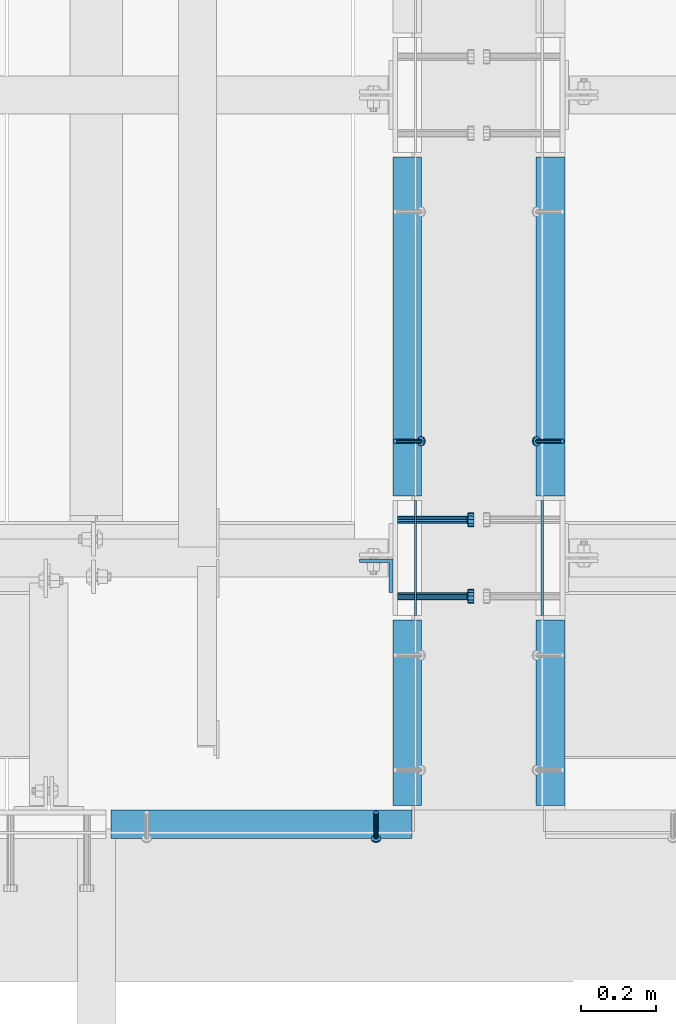
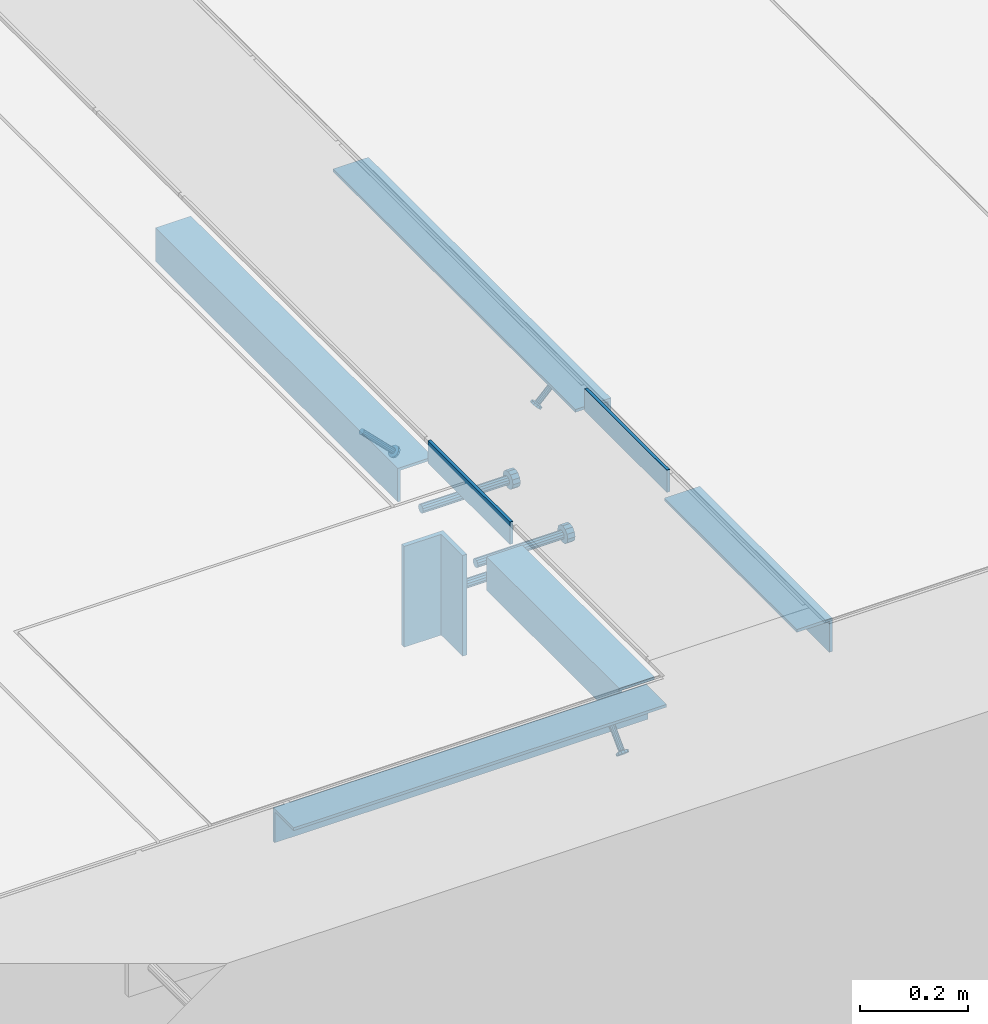
# One storey, part 2047 of 3843: 11 beams, 3 members, 8 elements without a shape of their own.
"""IFC2X3 building model written with IfcOpenShell, lengths in millimetres."""

import ifcopenshell
import ifcopenshell.guid

model = None  # the IFC model being written
_history = None  # IfcOwnerHistory: only IFC2X3 demands one
_inside = {}  # id of a spatial element -> (the spatial element, [elements in it])
_under = {}  # id of a project, library or spatial element -> (it, [spatial elements below it])
_declared = {}  # id of a project -> (the project, [libraries it declares])
_typed = {}  # id of a type object -> (the type object, [elements of that type])
_made_of = {}  # id of a material, layer set ... -> (it, [elements and type objects made of it])


def new_model(schema):
    """Start an empty IFC model of exactly this schema.

    Asked for "IFC4X3", IfcOpenShell would pick the latest addendum, in which some entities
    have other attributes; the version numbers below select the first issue.
    IFC2X3 requires an IfcOwnerHistory on every rooted entity: one is made here for all.
    """
    global model, _history
    if schema == "IFC4X3":
        model = ifcopenshell.file(schema_version=(4, 3, 0, 0))
    else:
        model = ifcopenshell.file(schema=schema)
    _inside.clear()
    _under.clear()
    _declared.clear()
    _typed.clear()
    _made_of.clear()
    _history = None
    if model.schema == "IFC2X3":
        org = make("IfcOrganization", Name="unknown")
        user = make(
            "IfcPersonAndOrganization",
            ThePerson=make("IfcPerson", FamilyName="unknown"),
            TheOrganization=org,
        )
        app = make(
            "IfcApplication",
            ApplicationDeveloper=org,
            Version="unknown",
            ApplicationFullName="unknown",
            ApplicationIdentifier="unknown",
        )
        _history = make(
            "IfcOwnerHistory",
            OwningUser=user,
            OwningApplication=app,
            ChangeAction="ADDED",
            CreationDate=0,
        )
    return model


def make(cls, **values):
    """One entity of the class cls with the attributes given. An attribute that is None is left unset."""
    return model.create_entity(
        cls, **{name: value for name, value in values.items() if value is not None}
    )


def rooted(cls, **values):
    """An entity with a GlobalId (a new one), such as an element, a storey or a relation."""
    return make(cls, GlobalId=ifcopenshell.guid.new(), OwnerHistory=_history, **values)


def si_unit(unit_type, name, prefix=None):
    """IfcSIUnit, for example si_unit("LENGTHUNIT", "METRE", prefix="MILLI")."""
    return make("IfcSIUnit", UnitType=unit_type, Prefix=prefix, Name=name)


def assignment(units):
    """IfcUnitAssignment: the units of a project."""
    return None if units is None else make("IfcUnitAssignment", Units=units)


def point(xyz):
    """IfcCartesianPoint."""
    return None if xyz is None else make("IfcCartesianPoint", Coordinates=xyz)


def direction(xyz):
    """IfcDirection."""
    return None if xyz is None else make("IfcDirection", DirectionRatios=xyz)


def frame(location, z_axis=None, x_axis=None):
    """IfcAxis2Placement3D, a coordinate frame: its origin and axes. An axis left out is left unset."""
    return make(
        "IfcAxis2Placement3D",
        Location=point(location),
        Axis=direction(z_axis),
        RefDirection=direction(x_axis),
    )


def origin_with_axes():
    """The frame at (0, 0, 0) with the z axis (0, 0, 1) and the x axis (1, 0, 0) written out."""
    return frame((0.0, 0.0, 0.0), z_axis=(0.0, 0.0, 1.0), x_axis=(1.0, 0.0, 0.0))


def place(relative_to, where):
    """IfcLocalPlacement: puts the frame where relative to a parent placement (None: the world)."""
    return make(
        "IfcLocalPlacement", PlacementRelTo=relative_to, RelativePlacement=where
    )


def context(
    kind, dimensions, precision=None, world=None, true_north=None, identifier=None
):
    """IfcGeometricRepresentationContext, for example the 3D "Model" context."""
    return make(
        "IfcGeometricRepresentationContext",
        ContextIdentifier=identifier,
        ContextType=kind,
        CoordinateSpaceDimension=dimensions,
        Precision=precision,
        WorldCoordinateSystem=world,
        TrueNorth=true_north,
    )


def subcontext(parent, identifier, kind, view, scale=None):
    """IfcGeometricRepresentationSubContext, for example "Body" below "Model"."""
    return make(
        "IfcGeometricRepresentationSubContext",
        ContextIdentifier=identifier,
        ContextType=kind,
        ParentContext=parent,
        TargetScale=scale,
        TargetView=view,
    )


def project(units=None, contexts=None):
    """IfcProject with its units and contexts."""
    return rooted(
        "IfcProject",
        Name="project",
        RepresentationContexts=contexts,
        UnitsInContext=assignment(units),
    )


def spatial(cls, under=None, at=None, **own):
    """A site, building, storey or space (cls), placed at a placement, below another one or the project."""
    s = rooted(cls, ObjectPlacement=at, **own)
    if under is not None:
        _under.setdefault(under.id(), (under, []))[1].append(s)
    return s


def faces_of(points, faces, orient=None, outer=None):
    """IfcFace entities. A face is a list of loops; a loop is a list of indices into points, from 0.

    orient and outer hold one flag for each loop. By default every Orientation is true, the
    first loop of a face is its IfcFaceOuterBound and the others are IfcFaceBound.
    """
    made = []
    for i, loops in enumerate(faces):
        bounds = []
        for j, loop in enumerate(loops):
            is_outer = j == 0 if outer is None else outer[i][j]
            bounds.append(
                make(
                    "IfcFaceOuterBound" if is_outer else "IfcFaceBound",
                    Bound=make("IfcPolyLoop", Polygon=[points[k] for k in loop]),
                    Orientation=True if orient is None else orient[i][j],
                )
            )
        made.append(make("IfcFace", Bounds=bounds))
    return made


def faceted_brep(points, faces, orient=None, outer=None, voids=None):
    """IfcFacetedBrep: a solid bounded by flat faces; with voids (closed shells), ...WithVoids."""
    shared = [point(p) for p in points]
    hull = make("IfcClosedShell", CfsFaces=faces_of(shared, faces, orient, outer))
    if voids is None:
        return make("IfcFacetedBrep", Outer=hull)
    return make(
        "IfcFacetedBrepWithVoids",
        Outer=hull,
        Voids=[
            make(cls, CfsFaces=faces_of(shared, fs, o, b)) for cls, fs, o, b in voids
        ],
    )


def shape(context_of_items, identifier, shape_type, items):
    """IfcShapeRepresentation: the items that make up one representation, for example the "Body"."""
    return make(
        "IfcShapeRepresentation",
        ContextOfItems=context_of_items,
        RepresentationIdentifier=identifier,
        RepresentationType=shape_type,
        Items=items,
    )


def material(Name=None, Category=None):
    """IfcMaterial."""
    return make("IfcMaterial", Name=Name, Category=Category)


def made_of(thing, what):
    """Note that an element or type object is made of a material, layer set ...; save() writes the relation."""
    if what is not None:
        _made_of.setdefault(what.id(), (what, []))[1].append(thing)
    return thing


def type_object(cls, material=None, **own):
    """A type object (cls), such as IfcWallType, which elements share."""
    return made_of(rooted(cls, **own), material)


def element(
    cls,
    number,
    at=None,
    inside=None,
    cuts=None,
    type_object=None,
    material=None,
    context=None,
    identifier="Body",
    shape_type=None,
    held_by="IfcProductDefinitionShape",
    body=None,
    shapes=None,
    **own,
):
    """One element of the class cls, such as IfcWall. Its Tag is "e" and its number.

    at: its placement. inside: the storey or other place that contains it. cuts: it is an
    opening in that element (IfcRelVoidsElement). A single representation is given by context,
    identifier, shape_type and body (its items); several are given by shapes. held_by: the class
    of the entity that holds the representations. save() writes the other relations.
    """
    e = rooted(cls, Tag="e%d" % number, ObjectPlacement=at, **own)
    if body is not None:
        shapes = [shape(context, identifier, shape_type, body)]
    if shapes is not None:
        e.Representation = make(held_by, Representations=shapes)
    if inside is not None:
        _inside.setdefault(inside.id(), (inside, []))[1].append(e)
    if cuts is not None:
        rooted(
            "IfcRelVoidsElement", RelatingBuildingElement=cuts, RelatedOpeningElement=e
        )
    if type_object is not None:
        _typed.setdefault(type_object.id(), (type_object, []))[1].append(e)
    return made_of(e, material)


def aggregate(whole, parts):
    """IfcRelAggregates: a whole, such as a stair, and the parts it consists of."""
    return rooted("IfcRelAggregates", RelatingObject=whole, RelatedObjects=parts)


def save(model, path):
    """Write the relations noted so far, then the file.

    IfcRelAggregates (storeys below a building ...), IfcRelContainedInSpatialStructure (elements
    in a storey), IfcRelDefinesByType, IfcRelAssociatesMaterial and IfcRelDeclares: one each for
    every whole, place, type object, material and project.
    """
    for whole, parts in _under.values():
        aggregate(whole, parts)
    for where, things in _inside.values():
        rooted(
            "IfcRelContainedInSpatialStructure",
            RelatedElements=things,
            RelatingStructure=where,
        )
    for kind, things in _typed.values():
        rooted("IfcRelDefinesByType", RelatedObjects=things, RelatingType=kind)
    for what, things in _made_of.values():
        rooted("IfcRelAssociatesMaterial", RelatedObjects=things, RelatingMaterial=what)
    for by, libraries in _declared.values():
        rooted("IfcRelDeclares", RelatingContext=by, RelatedDefinitions=libraries)
    model.write(path)


model = new_model("IFC2X3")

# Units and contexts
model_context = context("Model", 3, precision=1e-05, world=origin_with_axes())
body_context = subcontext(model_context, "Body", "Model", "MODEL_VIEW")
ifc_project = project(units=[si_unit("LENGTHUNIT", "METRE", prefix="MILLI"), si_unit("AREAUNIT", "SQUARE_METRE"), si_unit("VOLUMEUNIT", "CUBIC_METRE"), si_unit("MASSUNIT", "GRAM", prefix="KILO"), si_unit("TIMEUNIT", "SECOND"), si_unit("PLANEANGLEUNIT", "RADIAN"), si_unit("SOLIDANGLEUNIT", "STERADIAN"), si_unit("THERMODYNAMICTEMPERATUREUNIT", "DEGREE_CELSIUS"), si_unit("LUMINOUSINTENSITYUNIT", "LUMEN")], contexts=[model_context])

# Site, building, storey
site_placement = place(None, origin_with_axes())
site = spatial("IfcSite", under=ifc_project, at=site_placement, CompositionType="ELEMENT")
building_placement = place(site_placement, origin_with_axes())
building = spatial("IfcBuilding", under=site, at=building_placement, Name="Undefined", CompositionType="ELEMENT")
storey_placement = place(building_placement, origin_with_axes())
storey = spatial("IfcBuildingStorey", under=building, at=storey_placement, Name="Undefined", CompositionType="ELEMENT", Elevation=0.0)

# Assembly, beam
assembly_1_placement = place(storey_placement, origin_with_axes())
assembly_1 = element("IfcElementAssembly", 1, at=assembly_1_placement, inside=storey, Name="EMBED PLATE", AssemblyPlace="NOTDEFINED", PredefinedType="RIGID_FRAME")
ifc_material_1 = material(Name="STEEL/A36")
beam_type_1 = type_object("IfcBeamType", PredefinedType="NOTDEFINED")
beam_1_placement = place(assembly_1_placement, frame((59013.7249969482, 15151.1, 30454.6), z_axis=(0.0, 0.0, 1.0), x_axis=(0.0, -1.0, 0.0)))
beam_1 = element("IfcBeam", 2, at=beam_1_placement, type_object=beam_type_1, material=ifc_material_1, Name="PLATE", context=body_context, shape_type="Brep", body=[
    faceted_brep([(0.0, 3.17499999999927, -25.4000000000015), (0.0, 3.17499999999927, 25.4000000000015), (304.800000000003, 3.17500000000291, 25.4000000000015), (304.800000000003, 3.17500000000291, -25.4000000000015), (0.0, -3.17499999999927, 25.4000000000015), (304.800000000003, -3.17500000000291, 25.4000000000015), (0.0, -3.17499999999927, -25.4000000000015), (304.800000000003, -3.17500000000291, -25.4000000000015)], [[[0, 1, 2, 3]], [[1, 4, 5, 2]], [[4, 6, 7, 5]], [[6, 0, 3, 7]], [[5, 7, 3, 2]], [[6, 4, 1, 0]]]),
])

assembly_2_placement = place(storey_placement, origin_with_axes())
assembly_2 = element("IfcElementAssembly", 3, at=assembly_2_placement, inside=storey, Name="EMBED PLATE", AssemblyPlace="NOTDEFINED", PredefinedType="RIGID_FRAME")
beam_2_placement = place(assembly_2_placement, frame((59350.2750030518, 14846.3, 30454.6), z_axis=(0.0, 0.0, 1.0), x_axis=(0.0, 1.0, 0.0)))
beam_2 = element("IfcBeam", 4, at=beam_2_placement, type_object=beam_type_1, material=ifc_material_1, Name="PLATE", context=body_context, shape_type="Brep", body=[
    faceted_brep([(0.0, 3.17499999999927, -25.4000000000015), (0.0, 3.17499999999927, 25.4000000000015), (304.800000000003, 3.17500000000291, 25.4000000000015), (304.800000000003, 3.17500000000291, -25.4000000000015), (0.0, -3.17499999999927, 25.4000000000015), (304.800000000003, -3.17500000000291, 25.4000000000015), (0.0, -3.17499999999927, -25.4000000000015), (304.800000000003, -3.17500000000291, -25.4000000000015)], [[[0, 1, 2, 3]], [[1, 4, 5, 2]], [[4, 6, 7, 5]], [[6, 0, 3, 7]], [[5, 7, 3, 2]], [[6, 4, 1, 0]]]),
])
aggregate(assembly_2, [beam_2])

# Assembly, member
assembly_3_placement = place(storey_placement, origin_with_axes())
assembly_3 = element("IfcElementAssembly", 5, at=assembly_3_placement, inside=storey, Name="ANGLE", AssemblyPlace="NOTDEFINED", PredefinedType="RIGID_FRAME")
ifc_material_2 = material(Name="STEEL/A108")
member_type = type_object("IfcMemberType", PredefinedType="NOTDEFINED")
member_1_placement = place(assembly_3_placement, frame((59404.2499894523, 15309.0559967422, 30422.8500045777), z_axis=(0.0, -1.0, 0.0), x_axis=(-0.707106781186548, 0.0, -0.707106781186548)))
member_1 = element("IfcMember", 6, at=member_1_placement, type_object=member_type, material=ifc_material_2, Name="HEADED STUD ANCHOR", context=body_context, shape_type="Brep", body=[
    faceted_brep([(7.27595761418343e-12, -3.18000006675175, 5.5), (0.0, -5.49999999998363, 3.1800000667572), (94.4879985803855, -5.50000000011278, 3.1800000667572), (94.4879985803782, -3.18000006687362, 5.5), (0.0, -6.3499999046162, 0.0), (94.4879985803855, -6.34999990474535, 0.0), (0.0, -5.49999999998363, -3.1800000667572), (94.4879985803855, -5.50000000011278, -3.1800000667572), (7.27595761418343e-12, -3.18000006675175, -5.5), (94.4879985803782, -3.18000006687362, -5.5), (7.27595761418343e-12, -1.81898940354586e-12, -6.34999990463257), (94.4879985803782, -1.20053300634027e-10, -6.34999990463257), (0.0, 3.18000006675175, -5.5), (94.4879985803709, 3.18000006663351, -5.5), (7.27595761418343e-12, 5.49999999998363, -3.1800000667572), (94.4879985803709, 5.49999999987267, -3.1800000667572), (7.27595761418343e-12, 6.3499999046162, 0.0), (94.4879985803673, 6.34999990450706, 0.0), (7.27595761418343e-12, 5.49999999998363, 3.1800000667572), (94.4879985803709, 5.49999999987267, 3.1800000667572), (0.0, 3.18000006675175, 5.5), (94.4879985803709, 3.18000006663351, 5.5), (7.27595761418343e-12, -1.81898940354586e-12, 6.34999990463257), (94.4879985803782, -1.20053300634027e-10, 6.34999990463257), (96.5199985498621, -10.9899997712273, 6.34999990463257), (96.5199985498548, -6.34000015270249, 10.9899997711182), (96.5199985498621, -12.6999998093743, 0.0), (96.5199985498621, -10.9899997712273, -6.34999990463257), (96.5199985498548, -6.34000015270249, -10.9899997711182), (96.5199985498475, -1.21872290037572e-10, -12.6899995803833), (96.5199985498402, 6.34000015245874, -10.9899997711182), (96.519998549833, 10.9899997709817, -6.34999990463257), (96.519998549833, 12.6999998091305, 0.0), (96.519998549833, 10.9899997709817, 6.34999990463257), (96.5199985498402, 6.34000015245874, 10.9899997711182), (96.5199985498475, -1.21872290037572e-10, 12.6899995803833), (101.599998473539, -10.9899997712328, 6.34999990463257), (101.599998473532, -6.34000015270976, 10.9899997711182), (101.599998473539, -12.6999998093797, 0.0), (101.599998473539, -10.9899997712328, -6.34999990463257), (101.599998473532, -6.34000015270976, -10.9899997711182), (101.599998473524, -1.29148247651756e-10, -12.6899995803833), (101.599998473517, 6.34000015245329, -10.9899997711182), (101.59999847351, 10.9899997709763, -6.34999990463257), (101.599998473503, 12.6999998091196, 0.0), (101.59999847351, 10.9899997709763, 6.34999990463257), (101.599998473517, 6.34000015245329, 10.9899997711182), (101.599998473524, -1.29148247651756e-10, 12.6899995803833)], [[[0, 1, 2, 3]], [[1, 4, 5, 2]], [[4, 6, 7, 5]], [[6, 8, 9, 7]], [[8, 10, 11, 9]], [[10, 12, 13, 11]], [[12, 14, 15, 13]], [[14, 16, 17, 15]], [[16, 18, 19, 17]], [[18, 20, 21, 19]], [[20, 22, 23, 21]], [[22, 0, 3, 23]], [[22, 20, 18, 16, 14, 12, 10, 8, 6, 4, 1, 0]], [[3, 2, 24, 25]], [[2, 5, 26, 24]], [[5, 7, 27, 26]], [[7, 9, 28, 27]], [[9, 11, 29, 28]], [[11, 13, 30, 29]], [[13, 15, 31, 30]], [[15, 17, 32, 31]], [[17, 19, 33, 32]], [[19, 21, 34, 33]], [[21, 23, 35, 34]], [[23, 3, 25, 35]], [[25, 24, 36, 37]], [[24, 26, 38, 36]], [[26, 27, 39, 38]], [[27, 28, 40, 39]], [[28, 29, 41, 40]], [[29, 30, 42, 41]], [[30, 31, 43, 42]], [[31, 32, 44, 43]], [[32, 33, 45, 44]], [[33, 34, 46, 45]], [[34, 35, 47, 46]], [[35, 25, 37, 47]], [[38, 39, 40, 41, 42, 43, 44, 45, 46, 47, 37, 36]]]),
])

assembly_4_placement = place(storey_placement, origin_with_axes())
assembly_4 = element("IfcElementAssembly", 7, at=assembly_4_placement, inside=storey, Name="ANGLE", AssemblyPlace="NOTDEFINED", PredefinedType="RIGID_FRAME")
member_2_placement = place(assembly_4_placement, frame((58959.7500032937, 15309.056027729, 30422.8500045777), z_axis=(0.0, 1.0, 0.0), x_axis=(0.707106781186548, 0.0, -0.707106781186548)))
member_2 = element("IfcMember", 8, at=member_2_placement, type_object=member_type, material=ifc_material_2, Name="HEADED STUD ANCHOR", context=body_context, shape_type="Brep", body=[
    faceted_brep([(7.27595761418343e-12, -3.18000006675175, 5.5), (0.0, -5.49999999998363, 3.1800000667572), (94.4879985803855, -5.50000000011278, 3.1800000667572), (94.4879985803782, -3.18000006687362, 5.5), (0.0, -6.3499999046162, 0.0), (94.4879985803855, -6.34999990474535, 0.0), (0.0, -5.49999999998363, -3.1800000667572), (94.4879985803855, -5.50000000011278, -3.1800000667572), (7.27595761418343e-12, -3.18000006675175, -5.5), (94.4879985803782, -3.18000006687362, -5.5), (7.27595761418343e-12, -1.81898940354586e-12, -6.34999990463257), (94.4879985803782, -1.20053300634027e-10, -6.34999990463257), (0.0, 3.18000006675175, -5.5), (94.4879985803709, 3.18000006663351, -5.5), (7.27595761418343e-12, 5.49999999998363, -3.1800000667572), (94.4879985803709, 5.49999999987267, -3.1800000667572), (7.27595761418343e-12, 6.3499999046162, 0.0), (94.4879985803673, 6.34999990450706, 0.0), (7.27595761418343e-12, 5.49999999998363, 3.1800000667572), (94.4879985803709, 5.49999999987267, 3.1800000667572), (0.0, 3.18000006675175, 5.5), (94.4879985803709, 3.18000006663351, 5.5), (7.27595761418343e-12, -1.81898940354586e-12, 6.34999990463257), (94.4879985803782, -1.20053300634027e-10, 6.34999990463257), (96.5199985498621, -10.9899997712273, 6.34999990463257), (96.5199985498548, -6.34000015270249, 10.9899997711182), (96.5199985498621, -12.6999998093743, 0.0), (96.5199985498621, -10.9899997712273, -6.34999990463257), (96.5199985498548, -6.34000015270249, -10.9899997711182), (96.5199985498475, -1.21872290037572e-10, -12.6899995803833), (96.5199985498402, 6.34000015245874, -10.9899997711182), (96.519998549833, 10.9899997709817, -6.34999990463257), (96.519998549833, 12.6999998091305, 0.0), (96.519998549833, 10.9899997709817, 6.34999990463257), (96.5199985498402, 6.34000015245874, 10.9899997711182), (96.5199985498475, -1.21872290037572e-10, 12.6899995803833), (101.599998473539, -10.9899997712328, 6.34999990463257), (101.599998473532, -6.34000015270976, 10.9899997711182), (101.599998473539, -12.6999998093797, 0.0), (101.599998473539, -10.9899997712328, -6.34999990463257), (101.599998473532, -6.34000015270976, -10.9899997711182), (101.599998473524, -1.29148247651756e-10, -12.6899995803833), (101.599998473517, 6.34000015245329, -10.9899997711182), (101.59999847351, 10.9899997709763, -6.34999990463257), (101.599998473503, 12.6999998091196, 0.0), (101.59999847351, 10.9899997709763, 6.34999990463257), (101.599998473517, 6.34000015245329, 10.9899997711182), (101.599998473524, -1.29148247651756e-10, 12.6899995803833)], [[[0, 1, 2, 3]], [[1, 4, 5, 2]], [[4, 6, 7, 5]], [[6, 8, 9, 7]], [[8, 10, 11, 9]], [[10, 12, 13, 11]], [[12, 14, 15, 13]], [[14, 16, 17, 15]], [[16, 18, 19, 17]], [[18, 20, 21, 19]], [[20, 22, 23, 21]], [[22, 0, 3, 23]], [[22, 20, 18, 16, 14, 12, 10, 8, 6, 4, 1, 0]], [[3, 2, 24, 25]], [[2, 5, 26, 24]], [[5, 7, 27, 26]], [[7, 9, 28, 27]], [[9, 11, 29, 28]], [[11, 13, 30, 29]], [[13, 15, 31, 30]], [[15, 17, 32, 31]], [[17, 19, 33, 32]], [[19, 21, 34, 33]], [[21, 23, 35, 34]], [[23, 3, 25, 35]], [[25, 24, 36, 37]], [[24, 26, 38, 36]], [[26, 27, 39, 38]], [[27, 28, 40, 39]], [[28, 29, 41, 40]], [[29, 30, 42, 41]], [[30, 31, 43, 42]], [[31, 32, 44, 43]], [[32, 33, 45, 44]], [[33, 34, 46, 45]], [[34, 35, 47, 46]], [[35, 25, 37, 47]], [[38, 39, 40, 41, 42, 43, 44, 45, 46, 47, 37, 36]]]),
])

# Assembly, member, beam
assembly_5_placement = place(storey_placement, origin_with_axes())
assembly_5 = element("IfcElementAssembly", 9, at=assembly_5_placement, inside=storey, Name="ANGLE", AssemblyPlace="NOTDEFINED", PredefinedType="RIGID_FRAME")
member_3_placement = place(assembly_5_placement, frame((58908.9500082383, 14322.4244471697, 30422.8500024177), z_axis=(1.0, 0.0, 0.0), x_axis=(0.0, -0.707106781186548, -0.707106781186548)))
member_3 = element("IfcMember", 10, at=member_3_placement, type_object=member_type, material=ifc_material_2, Name="HEADED STUD ANCHOR", context=body_context, shape_type="Brep", body=[
    faceted_brep([(7.27595761418343e-12, -3.18000006675175, 5.5), (0.0, -5.49999999998363, 3.1800000667572), (94.4879985803855, -5.50000000011278, 3.1800000667572), (94.4879985803782, -3.18000006687362, 5.5), (0.0, -6.3499999046162, 0.0), (94.4879985803855, -6.34999990474535, 0.0), (0.0, -5.49999999998363, -3.1800000667572), (94.4879985803855, -5.50000000011278, -3.1800000667572), (7.27595761418343e-12, -3.18000006675175, -5.5), (94.4879985803782, -3.18000006687362, -5.5), (7.27595761418343e-12, -1.81898940354586e-12, -6.34999990463257), (94.4879985803782, -1.20053300634027e-10, -6.34999990463257), (0.0, 3.18000006675175, -5.5), (94.4879985803709, 3.18000006663351, -5.5), (7.27595761418343e-12, 5.49999999998363, -3.1800000667572), (94.4879985803709, 5.49999999987267, -3.1800000667572), (7.27595761418343e-12, 6.3499999046162, 0.0), (94.4879985803673, 6.34999990450706, 0.0), (7.27595761418343e-12, 5.49999999998363, 3.1800000667572), (94.4879985803709, 5.49999999987267, 3.1800000667572), (0.0, 3.18000006675175, 5.5), (94.4879985803709, 3.18000006663351, 5.5), (7.27595761418343e-12, -1.81898940354586e-12, 6.34999990463257), (94.4879985803782, -1.20053300634027e-10, 6.34999990463257), (96.5199985498621, -10.9899997712273, 6.34999990463257), (96.5199985498548, -6.34000015270249, 10.9899997711182), (96.5199985498621, -12.6999998093743, 0.0), (96.5199985498621, -10.9899997712273, -6.34999990463257), (96.5199985498548, -6.34000015270249, -10.9899997711182), (96.5199985498475, -1.21872290037572e-10, -12.6899995803833), (96.5199985498402, 6.34000015245874, -10.9899997711182), (96.519998549833, 10.9899997709817, -6.34999990463257), (96.519998549833, 12.6999998091305, 0.0), (96.519998549833, 10.9899997709817, 6.34999990463257), (96.5199985498402, 6.34000015245874, 10.9899997711182), (96.5199985498475, -1.21872290037572e-10, 12.6899995803833), (101.599998473539, -10.9899997712328, 6.34999990463257), (101.599998473532, -6.34000015270976, 10.9899997711182), (101.599998473539, -12.6999998093797, 0.0), (101.599998473539, -10.9899997712328, -6.34999990463257), (101.599998473532, -6.34000015270976, -10.9899997711182), (101.599998473524, -1.29148247651756e-10, -12.6899995803833), (101.599998473517, 6.34000015245329, -10.9899997711182), (101.59999847351, 10.9899997709763, -6.34999990463257), (101.599998473503, 12.6999998091196, 0.0), (101.59999847351, 10.9899997709763, 6.34999990463257), (101.599998473517, 6.34000015245329, 10.9899997711182), (101.599998473524, -1.29148247651756e-10, 12.6899995803833)], [[[0, 1, 2, 3]], [[1, 4, 5, 2]], [[4, 6, 7, 5]], [[6, 8, 9, 7]], [[8, 10, 11, 9]], [[10, 12, 13, 11]], [[12, 14, 15, 13]], [[14, 16, 17, 15]], [[16, 18, 19, 17]], [[18, 20, 21, 19]], [[20, 22, 23, 21]], [[22, 0, 3, 23]], [[22, 20, 18, 16, 14, 12, 10, 8, 6, 4, 1, 0]], [[3, 2, 24, 25]], [[2, 5, 26, 24]], [[5, 7, 27, 26]], [[7, 9, 28, 27]], [[9, 11, 29, 28]], [[11, 13, 30, 29]], [[13, 15, 31, 30]], [[15, 17, 32, 31]], [[17, 19, 33, 32]], [[19, 21, 34, 33]], [[21, 23, 35, 34]], [[23, 3, 25, 35]], [[25, 24, 36, 37]], [[24, 26, 38, 36]], [[26, 27, 39, 38]], [[27, 28, 40, 39]], [[28, 29, 41, 40]], [[29, 30, 42, 41]], [[30, 31, 43, 42]], [[31, 32, 44, 43]], [[32, 33, 45, 44]], [[33, 34, 46, 45]], [[34, 35, 47, 46]], [[35, 25, 37, 47]], [[38, 39, 40, 41, 42, 43, 44, 45, 46, 47, 37, 36]]]),
])
beam_type_2 = type_object("IfcBeamType", Name="L3X3X1/4", PredefinedType="NOTDEFINED")
beam_3_placement = place(assembly_5_placement, frame((59004.2000268618, 14290.6743995893, 30391.1000030518), z_axis=(0.0, 0.0, -1.0), x_axis=(-1.0, 0.0, 0.0)))
beam_3 = element("IfcBeam", 11, at=beam_3_placement, type_object=beam_type_2, material=ifc_material_1, Name="ANGLE", ObjectType="L3X3X1/4", context=body_context, shape_type="Brep", body=[
    faceted_brep([(0.0, 38.0999999999985, -38.0999999999985), (0.0, 38.0999999999985, 38.0999999999985), (800.10003051789, 38.0999999998003, 38.0999999999985), (800.10003051789, 38.0999999998003, -38.0999999999985), (0.0, 31.75, 38.0999999999985), (800.100030517875, 31.7499999997999, 38.0999999999985), (0.0, 31.75, -31.75), (800.100030517875, 31.7499999997999, -31.75), (0.0, -38.0999999999985, -31.75), (800.100030517729, -38.1000000002023, -31.75), (0.0, -38.0999999999985, -38.0999999999985), (800.100030517729, -38.1000000002023, -38.0999999999985)], [[[0, 1, 2, 3]], [[1, 4, 5, 2]], [[4, 6, 7, 5]], [[6, 8, 9, 7]], [[8, 10, 11, 9]], [[10, 0, 3, 11]], [[5, 7, 9, 11, 3, 2]], [[10, 8, 6, 4, 1, 0]]]),
])
aggregate(assembly_5, [member_3, beam_3])

# Assembly, beam
assembly_6_placement = place(storey_placement, origin_with_axes())
assembly_6 = element("IfcElementAssembly", 12, at=assembly_6_placement, inside=storey, Name="ANGLE", AssemblyPlace="NOTDEFINED", PredefinedType="RIGID_FRAME")
beam_4_placement = place(assembly_6_placement, frame((59372.499994824, 14341.4750004191, 30391.1000045777), z_axis=(0.0, 0.0, -1.0), x_axis=(0.0, 1.0, 0.0)))
beam_4 = element("IfcBeam", 13, at=beam_4_placement, type_object=beam_type_2, material=ifc_material_1, Name="ANGLE", ObjectType="L3X3X1/4", context=body_context, shape_type="Brep", body=[
    faceted_brep([(0.0, 38.0999999999985, -38.0999999999985), (0.0, 38.0999999999985, 38.0999999999985), (492.1249897337, 38.1000000025524, 38.0999999999985), (492.1249897337, 38.1000000025524, -38.0999999999985), (0.0, 31.75, 38.0999999999985), (492.124989733698, 31.7500000025466, 38.0999999999985), (0.0, 31.75, -31.75), (492.124989733698, 31.7500000025466, -31.75), (0.0, -38.0999999999985, -31.75), (492.124989733675, -38.0999999974447, -31.75), (0.0, -38.0999999999985, -38.0999999999985), (492.124989733675, -38.0999999974447, -38.0999999999985)], [[[0, 1, 2, 3]], [[1, 4, 5, 2]], [[4, 6, 7, 5]], [[6, 8, 9, 7]], [[8, 10, 11, 9]], [[10, 0, 3, 11]], [[5, 7, 9, 11, 3, 2]], [[10, 8, 6, 4, 1, 0]]]),
])
aggregate(assembly_6, [beam_4])

# Beam
beam_5_placement = place(assembly_3_placement, frame((59372.4999885807, 15163.8000002286, 30391.1000045777), z_axis=(0.0, 0.0, -1.0), x_axis=(0.0, 1.0, 0.0)))
beam_5 = element("IfcBeam", 14, at=beam_5_placement, type_object=beam_type_2, material=ifc_material_1, Name="ANGLE", ObjectType="L3X3X1/4", context=body_context, shape_type="Brep", body=[
    faceted_brep([(0.0, 38.0999999999985, -38.0999999999985), (0.0, 38.0999999999985, 38.0999999999985), (900.112000000037, 38.1000000023996, 38.0999999999985), (900.112000000037, 38.1000000023996, -38.0999999999985), (0.0, 31.75, 38.0999999999985), (900.11200000003, 31.7500000023938, 38.0999999999985), (0.0, 31.75, -31.75), (900.11200000003, 31.7500000023938, -31.75), (0.0, -38.0999999999985, -31.75), (900.111999999965, -38.0999999976048, -31.75), (0.0, -38.0999999999985, -38.0999999999985), (900.111999999965, -38.0999999976048, -38.0999999999985)], [[[0, 1, 2, 3]], [[1, 4, 5, 2]], [[4, 6, 7, 5]], [[6, 8, 9, 7]], [[8, 10, 11, 9]], [[10, 0, 3, 11]], [[5, 7, 9, 11, 3, 2]], [[10, 8, 6, 4, 1, 0]]]),
])

aggregate(assembly_3, [member_1, beam_5])

# Assembly, beam
assembly_7_placement = place(storey_placement, origin_with_axes())
assembly_7 = element("IfcElementAssembly", 15, at=assembly_7_placement, inside=storey, Name="ANGLE", AssemblyPlace="NOTDEFINED", PredefinedType="RIGID_FRAME")
beam_6_placement = place(assembly_7_placement, frame((58991.5000010307, 14833.6000001905, 30391.1000045777), z_axis=(0.0, 0.0, -1.0), x_axis=(0.0, -1.0, 0.0)))
beam_6 = element("IfcBeam", 16, at=beam_6_placement, type_object=beam_type_2, material=ifc_material_1, Name="ANGLE", ObjectType="L3X3X1/4", context=body_context, shape_type="Brep", body=[
    faceted_brep([(0.0, 38.0999999999985, -38.0999999999985), (0.0, 38.0999999999985, 38.0999999999985), (492.1249897337, 38.1000000025524, 38.0999999999985), (492.1249897337, 38.1000000025524, -38.0999999999985), (0.0, 31.75, 38.0999999999985), (492.124989733698, 31.7500000025466, 38.0999999999985), (0.0, 31.75, -31.75), (492.124989733698, 31.7500000025466, -31.75), (0.0, -38.0999999999985, -31.75), (492.124989733675, -38.0999999974447, -31.75), (0.0, -38.0999999999985, -38.0999999999985), (492.124989733675, -38.0999999974447, -38.0999999999985)], [[[0, 1, 2, 3]], [[1, 4, 5, 2]], [[4, 6, 7, 5]], [[6, 8, 9, 7]], [[8, 10, 11, 9]], [[10, 0, 3, 11]], [[5, 7, 9, 11, 3, 2]], [[10, 8, 6, 4, 1, 0]]]),
])
aggregate(assembly_7, [beam_6])

# Beam
beam_7_placement = place(assembly_4_placement, frame((58991.5000010307, 16063.9120001141, 30391.1000045777), z_axis=(0.0, 0.0, -1.0), x_axis=(0.0, -1.0, 0.0)))
beam_7 = element("IfcBeam", 17, at=beam_7_placement, type_object=beam_type_2, material=ifc_material_1, Name="ANGLE", ObjectType="L3X3X1/4", context=body_context, shape_type="Brep", body=[
    faceted_brep([(0.0, 38.0999999999985, -38.0999999999985), (0.0, 38.0999999999985, 38.0999999999985), (900.112000000037, 38.1000000023996, 38.0999999999985), (900.112000000037, 38.1000000023996, -38.0999999999985), (0.0, 31.75, 38.0999999999985), (900.11200000003, 31.7500000023938, 38.0999999999985), (0.0, 31.75, -31.75), (900.11200000003, 31.7500000023938, -31.75), (0.0, -38.0999999999985, -31.75), (900.111999999965, -38.0999999976048, -31.75), (0.0, -38.0999999999985, -38.0999999999985), (900.111999999965, -38.0999999976048, -38.0999999999985)], [[[0, 1, 2, 3]], [[1, 4, 5, 2]], [[4, 6, 7, 5]], [[6, 8, 9, 7]], [[8, 10, 11, 9]], [[10, 0, 3, 11]], [[5, 7, 9, 11, 3, 2]], [[10, 8, 6, 4, 1, 0]]]),
])

aggregate(assembly_4, [member_2, beam_7])

# Assembly, beam
assembly_8_placement = place(storey_placement, origin_with_axes())
assembly_8 = element("IfcElementAssembly", 18, at=assembly_8_placement, inside=storey, Name="BEAM", AssemblyPlace="NOTDEFINED", PredefinedType="RIGID_FRAME")
beam_type_3 = type_object("IfcBeamType", Name="L3-1/2X3-1/2X3/8", PredefinedType="NOTDEFINED")
beam_8_placement = place(assembly_8_placement, frame((58908.9499969483, 14951.075, 30391.1), z_axis=(0.0, -1.0, 0.0), x_axis=(0.0, 0.0, -1.0)))
beam_8 = element("IfcBeam", 19, at=beam_8_placement, type_object=beam_type_3, material=ifc_material_1, Name="ANGLE", ObjectType="L3-1/2X3-1/2X3/8", context=body_context, shape_type="Brep", body=[
    faceted_brep([(-3.63797880709171e-12, 44.4499999999971, -44.4500000000007), (-3.63797880709171e-12, 44.4499999999971, 44.4500000000007), (228.600000000006, 44.4499999999971, 44.4500000000007), (228.600000000006, 44.4499999999971, -44.4500000000007), (0.0, 34.9250000000029, 44.4500000000007), (228.600000000006, 34.9250000000029, 44.4500000000007), (0.0, 34.9250000000029, -34.9250000000029), (228.600000000006, 34.9250000000029, -34.9249999999993), (0.0, -44.4499999999971, -34.9249999999993), (228.600000000006, -44.4499999999971, -34.9249999999993), (3.63797880709171e-12, -44.4499999999971, -44.4500000000007), (228.600000000006, -44.4499999999971, -44.4500000000007)], [[[0, 1, 2, 3]], [[1, 4, 5, 2]], [[4, 6, 7, 5]], [[6, 8, 9, 7]], [[8, 10, 11, 9]], [[10, 0, 3, 11]], [[5, 7, 9, 11, 3, 2]], [[10, 8, 6, 4, 1, 0]]]),
])
aggregate(assembly_8, [beam_8])

# Beam
beam_type_4 = type_object("IfcBeamType", PredefinedType="NOTDEFINED")
beam_9_placement = place(assembly_1_placement, frame((58966.0999969482, 15100.3, 30372.05), z_axis=(0.0, 1.0, 0.0), x_axis=(1.0, 0.0, 0.0)))
beam_9 = element("IfcBeam", 20, at=beam_9_placement, type_object=beam_type_4, material=ifc_material_2, Name="HEADED STUD ANCHOR", context=body_context, shape_type="Brep", body=[
    faceted_brep([(0.0, -9.52000045776367, 0.0), (0.0, -8.25, -4.76000022888184), (184.912000000004, -8.25, -4.76000022888184), (184.912000000004, -9.52000045776367, 0.0), (0.0, -4.76000022888184, -8.25), (184.912000000004, -4.76000022888184, -8.25), (0.0, 0.0, -9.52000045776367), (184.912000000004, 0.0, -9.52000045776367), (0.0, 4.76000022888184, -8.25), (184.912000000004, 4.76000022888184, -8.25), (0.0, 8.25, -4.76000022888184), (184.912000000004, 8.25, -4.76000022888184), (0.0, 9.52000045776367, 0.0), (184.912000000004, 9.52000045776367, 0.0), (0.0, 8.25, 4.76000022888184), (184.912000000004, 8.25, 4.76000022888184), (0.0, 4.76000022888184, 8.25), (184.912000000004, 4.76000022888184, 8.25), (0.0, 0.0, 9.52000045776367), (184.912000000004, 0.0, 9.52000045776367), (0.0, -4.76000022888184, 8.25), (184.912000000004, -4.76000022888184, 8.25), (0.0, -8.25, 4.76000022888184), (184.912000000004, -8.25, 4.76000022888184), (186.944000000003, -16.5, -9.52000045776367), (186.944000000003, -19.0499992370605, 0.0), (186.944000000003, -9.52000045776367, -16.5), (186.944000000003, 0.0, -19.0499992370605), (186.944000000003, 9.52000045776367, -16.5), (186.944000000003, 16.5, -9.52000045776367), (186.944000000003, 19.0499992370605, 0.0), (186.944000000003, 16.5, 9.52000045776367), (186.944000000003, 9.52000045776367, 16.5), (186.944000000003, 0.0, 19.0499992370605), (186.944000000003, -9.52000045776367, 16.5), (186.944000000003, -16.5, 9.52000045776367), (203.199999999997, -16.5, -9.52000045776367), (203.199999999997, -19.0499992370605, 0.0), (203.199999999997, -9.52000045776367, -16.5), (203.199999999997, 0.0, -19.0499992370605), (203.199999999997, 9.52000045776367, -16.5), (203.199999999997, 16.5, -9.52000045776367), (203.199999999997, 19.0499992370605, 0.0), (203.199999999997, 16.5, 9.52000045776367), (203.199999999997, 9.52000045776367, 16.5), (203.199999999997, 0.0, 19.0499992370605), (203.199999999997, -9.52000045776367, 16.5), (203.199999999997, -16.5, 9.52000045776367)], [[[0, 1, 2, 3]], [[1, 4, 5, 2]], [[4, 6, 7, 5]], [[6, 8, 9, 7]], [[8, 10, 11, 9]], [[10, 12, 13, 11]], [[12, 14, 15, 13]], [[14, 16, 17, 15]], [[16, 18, 19, 17]], [[18, 20, 21, 19]], [[20, 22, 23, 21]], [[22, 0, 3, 23]], [[22, 20, 18, 16, 14, 12, 10, 8, 6, 4, 1, 0]], [[3, 2, 24, 25]], [[2, 5, 26, 24]], [[5, 7, 27, 26]], [[7, 9, 28, 27]], [[9, 11, 29, 28]], [[11, 13, 30, 29]], [[13, 15, 31, 30]], [[15, 17, 32, 31]], [[17, 19, 33, 32]], [[19, 21, 34, 33]], [[21, 23, 35, 34]], [[23, 3, 25, 35]], [[25, 24, 36, 37]], [[24, 26, 38, 36]], [[26, 27, 39, 38]], [[27, 28, 40, 39]], [[28, 29, 41, 40]], [[29, 30, 42, 41]], [[30, 31, 43, 42]], [[31, 32, 44, 43]], [[32, 33, 45, 44]], [[33, 34, 46, 45]], [[34, 35, 47, 46]], [[35, 25, 37, 47]], [[38, 39, 40, 41, 42, 43, 44, 45, 46, 47, 37, 36]]]),
])

beam_10_placement = place(assembly_1_placement, frame((58966.0999969482, 15100.3, 30168.85), z_axis=(0.0, 1.0, 0.0), x_axis=(1.0, 0.0, 0.0)))
beam_10 = element("IfcBeam", 21, at=beam_10_placement, type_object=beam_type_4, material=ifc_material_2, Name="HEADED STUD ANCHOR", context=body_context, shape_type="Brep", body=[
    faceted_brep([(0.0, -9.52000045776367, 0.0), (0.0, -8.25, -4.76000022888184), (184.912000000004, -8.25, -4.76000022888184), (184.912000000004, -9.52000045776367, 0.0), (0.0, -4.76000022888184, -8.25), (184.912000000004, -4.76000022888184, -8.25), (0.0, 0.0, -9.52000045776367), (184.912000000004, 0.0, -9.52000045776367), (0.0, 4.76000022888184, -8.25), (184.912000000004, 4.76000022888184, -8.25), (0.0, 8.25, -4.76000022888184), (184.912000000004, 8.25, -4.76000022888184), (0.0, 9.52000045776367, 0.0), (184.912000000004, 9.52000045776367, 0.0), (0.0, 8.25, 4.76000022888184), (184.912000000004, 8.25, 4.76000022888184), (0.0, 4.76000022888184, 8.25), (184.912000000004, 4.76000022888184, 8.25), (0.0, 0.0, 9.52000045776367), (184.912000000004, 0.0, 9.52000045776367), (0.0, -4.76000022888184, 8.25), (184.912000000004, -4.76000022888184, 8.25), (0.0, -8.25, 4.76000022888184), (184.912000000004, -8.25, 4.76000022888184), (186.944000000003, -16.5, -9.52000045776367), (186.944000000003, -19.0499992370605, 0.0), (186.944000000003, -9.52000045776367, -16.5), (186.944000000003, 0.0, -19.0499992370605), (186.944000000003, 9.52000045776367, -16.5), (186.944000000003, 16.5, -9.52000045776367), (186.944000000003, 19.0499992370605, 0.0), (186.944000000003, 16.5, 9.52000045776367), (186.944000000003, 9.52000045776367, 16.5), (186.944000000003, 0.0, 19.0499992370605), (186.944000000003, -9.52000045776367, 16.5), (186.944000000003, -16.5, 9.52000045776367), (203.199999999997, -16.5, -9.52000045776367), (203.199999999997, -19.0499992370605, 0.0), (203.199999999997, -9.52000045776367, -16.5), (203.199999999997, 0.0, -19.0499992370605), (203.199999999997, 9.52000045776367, -16.5), (203.199999999997, 16.5, -9.52000045776367), (203.199999999997, 19.0499992370605, 0.0), (203.199999999997, 16.5, 9.52000045776367), (203.199999999997, 9.52000045776367, 16.5), (203.199999999997, 0.0, 19.0499992370605), (203.199999999997, -9.52000045776367, 16.5), (203.199999999997, -16.5, 9.52000045776367)], [[[0, 1, 2, 3]], [[1, 4, 5, 2]], [[4, 6, 7, 5]], [[6, 8, 9, 7]], [[8, 10, 11, 9]], [[10, 12, 13, 11]], [[12, 14, 15, 13]], [[14, 16, 17, 15]], [[16, 18, 19, 17]], [[18, 20, 21, 19]], [[20, 22, 23, 21]], [[22, 0, 3, 23]], [[22, 20, 18, 16, 14, 12, 10, 8, 6, 4, 1, 0]], [[3, 2, 24, 25]], [[2, 5, 26, 24]], [[5, 7, 27, 26]], [[7, 9, 28, 27]], [[9, 11, 29, 28]], [[11, 13, 30, 29]], [[13, 15, 31, 30]], [[15, 17, 32, 31]], [[17, 19, 33, 32]], [[19, 21, 34, 33]], [[21, 23, 35, 34]], [[23, 3, 25, 35]], [[25, 24, 36, 37]], [[24, 26, 38, 36]], [[26, 27, 39, 38]], [[27, 28, 40, 39]], [[28, 29, 41, 40]], [[29, 30, 42, 41]], [[30, 31, 43, 42]], [[31, 32, 44, 43]], [[32, 33, 45, 44]], [[33, 34, 46, 45]], [[34, 35, 47, 46]], [[35, 25, 37, 47]], [[38, 39, 40, 41, 42, 43, 44, 45, 46, 47, 37, 36]]]),
])

beam_11_placement = place(assembly_1_placement, frame((58966.0999969482, 14897.1, 30372.05), z_axis=(0.0, 1.0, 0.0), x_axis=(1.0, 0.0, 0.0)))
beam_11 = element("IfcBeam", 22, at=beam_11_placement, type_object=beam_type_4, material=ifc_material_1, Name="PLATE", context=body_context, shape_type="Brep", body=[
    faceted_brep([(0.0, -9.52000045776367, 0.0), (0.0, -8.25, -4.76000022888184), (184.912000000004, -8.25, -4.76000022888184), (184.912000000004, -9.52000045776367, 0.0), (0.0, -4.76000022888184, -8.25), (184.912000000004, -4.76000022888184, -8.25), (0.0, 0.0, -9.52000045776367), (184.912000000004, 0.0, -9.52000045776367), (0.0, 4.76000022888184, -8.25), (184.912000000004, 4.76000022888184, -8.25), (0.0, 8.25, -4.76000022888184), (184.912000000004, 8.25, -4.76000022888184), (0.0, 9.52000045776367, 0.0), (184.912000000004, 9.52000045776367, 0.0), (0.0, 8.25, 4.76000022888184), (184.912000000004, 8.25, 4.76000022888184), (0.0, 4.76000022888184, 8.25), (184.912000000004, 4.76000022888184, 8.25), (0.0, 0.0, 9.52000045776367), (184.912000000004, 0.0, 9.52000045776367), (0.0, -4.76000022888184, 8.25), (184.912000000004, -4.76000022888184, 8.25), (0.0, -8.25, 4.76000022888184), (184.912000000004, -8.25, 4.76000022888184), (186.944000000003, -16.5, -9.52000045776367), (186.944000000003, -19.0499992370605, 0.0), (186.944000000003, -9.52000045776367, -16.5), (186.944000000003, 0.0, -19.0499992370605), (186.944000000003, 9.52000045776367, -16.5), (186.944000000003, 16.5, -9.52000045776367), (186.944000000003, 19.0499992370605, 0.0), (186.944000000003, 16.5, 9.52000045776367), (186.944000000003, 9.52000045776367, 16.5), (186.944000000003, 0.0, 19.0499992370605), (186.944000000003, -9.52000045776367, 16.5), (186.944000000003, -16.5, 9.52000045776367), (203.199999999997, -16.5, -9.52000045776367), (203.199999999997, -19.0499992370605, 0.0), (203.199999999997, -9.52000045776367, -16.5), (203.199999999997, 0.0, -19.0499992370605), (203.199999999997, 9.52000045776367, -16.5), (203.199999999997, 16.5, -9.52000045776367), (203.199999999997, 19.0499992370605, 0.0), (203.199999999997, 16.5, 9.52000045776367), (203.199999999997, 9.52000045776367, 16.5), (203.199999999997, 0.0, 19.0499992370605), (203.199999999997, -9.52000045776367, 16.5), (203.199999999997, -16.5, 9.52000045776367)], [[[0, 1, 2, 3]], [[1, 4, 5, 2]], [[4, 6, 7, 5]], [[6, 8, 9, 7]], [[8, 10, 11, 9]], [[10, 12, 13, 11]], [[12, 14, 15, 13]], [[14, 16, 17, 15]], [[16, 18, 19, 17]], [[18, 20, 21, 19]], [[20, 22, 23, 21]], [[22, 0, 3, 23]], [[22, 20, 18, 16, 14, 12, 10, 8, 6, 4, 1, 0]], [[3, 2, 24, 25]], [[2, 5, 26, 24]], [[5, 7, 27, 26]], [[7, 9, 28, 27]], [[9, 11, 29, 28]], [[11, 13, 30, 29]], [[13, 15, 31, 30]], [[15, 17, 32, 31]], [[17, 19, 33, 32]], [[19, 21, 34, 33]], [[21, 23, 35, 34]], [[23, 3, 25, 35]], [[25, 24, 36, 37]], [[24, 26, 38, 36]], [[26, 27, 39, 38]], [[27, 28, 40, 39]], [[28, 29, 41, 40]], [[29, 30, 42, 41]], [[30, 31, 43, 42]], [[31, 32, 44, 43]], [[32, 33, 45, 44]], [[33, 34, 46, 45]], [[34, 35, 47, 46]], [[35, 25, 37, 47]], [[38, 39, 40, 41, 42, 43, 44, 45, 46, 47, 37, 36]]]),
])

aggregate(assembly_1, [beam_1, beam_9, beam_10, beam_11])

save(model, "model.ifc")
